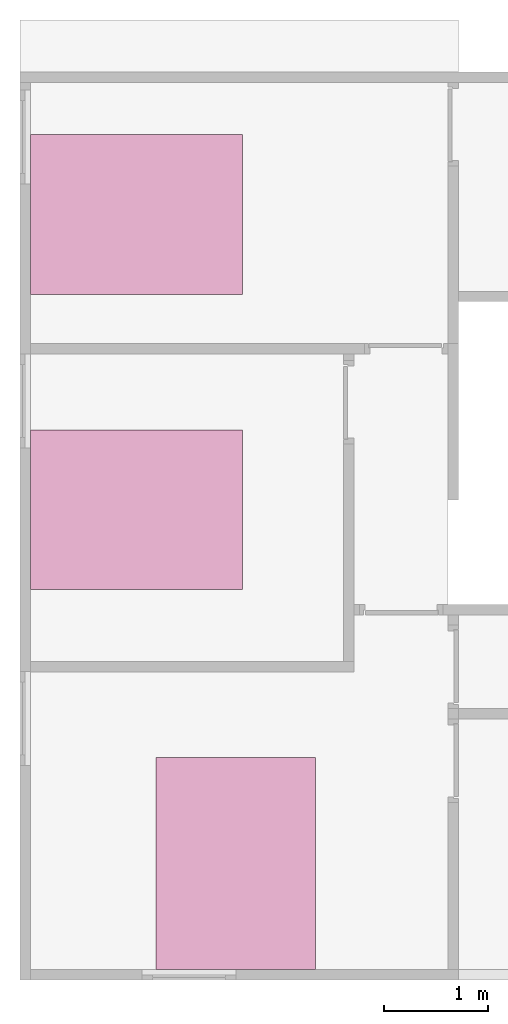
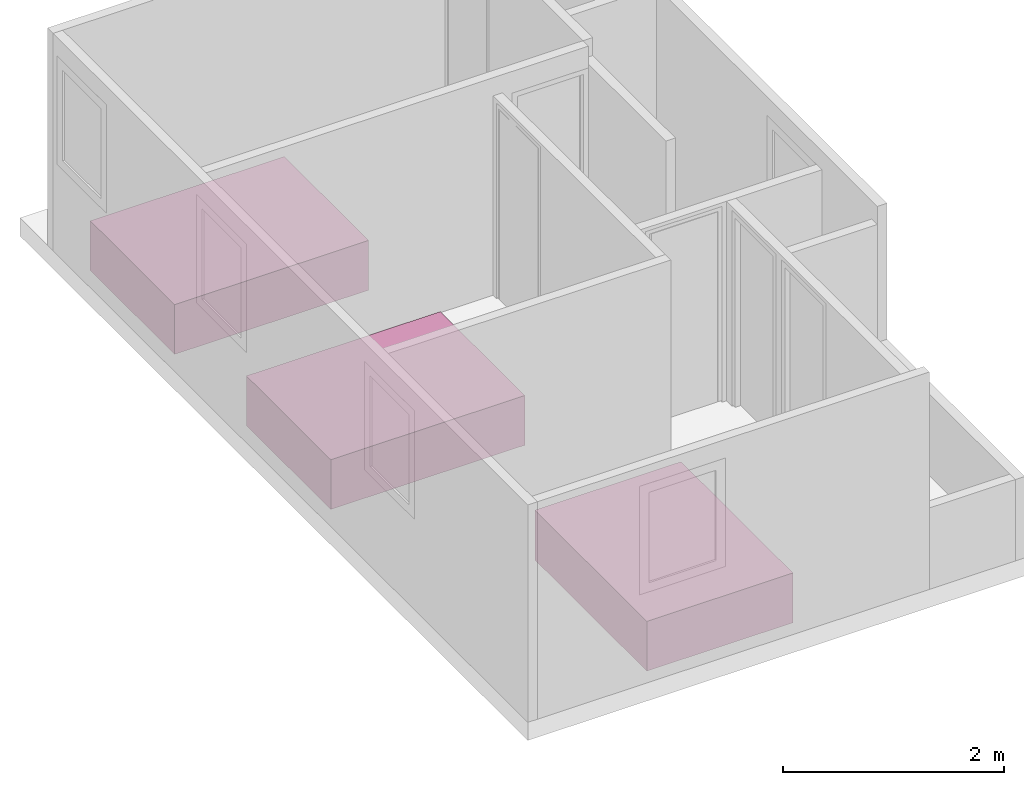
# One storey, part 3 of 3: 3 furniture elements.
"""IFC4 building model written with IfcOpenShell, lengths in millimetres."""

from ifc_helpers import new_model, entity, si_unit, converted_unit, frame, origin_with_axes, origin_2d_with_axis, place, context, subcontext, project, spatial, line, indexed_curve, outline, extrude, source, transform, mapped, type_object, type_shapes, element, save


model = new_model("IFC4")

# Units and contexts
model_context = context("Model", 3, precision=1e-05, world=origin_with_axes())
plan_context = context("Plan", 2, precision=1e-05, world=origin_2d_with_axis())
body_context = subcontext(model_context, "Body", "Model", "MODEL_VIEW")
ifc_project = project(units=[si_unit("LENGTHUNIT", "METRE", prefix="MILLI"), converted_unit("PLANEANGLEUNIT", "degree", entity("IfcReal", 0.0174532925199433), si_unit("PLANEANGLEUNIT", "RADIAN"), dimensions=[0, 0, 0, 0, 0, 0, 0]), si_unit("AREAUNIT", "SQUARE_METRE", prefix="MILLI"), si_unit("VOLUMEUNIT", "CUBIC_METRE", prefix="MILLI")], contexts=[model_context, plan_context])

# Site, building, storey
site_placement = place(None, origin_with_axes())
site = spatial("IfcSite", under=ifc_project, at=site_placement)
building_placement = place(site_placement, origin_with_axes())
building = spatial("IfcBuilding", under=site, at=building_placement, Name="Building")
storey_placement = place(building_placement, frame((0.0, 0.0, 4810.0004196167), z_axis=(0.0, 0.0, 1.0), x_axis=(1.0, 0.0, 0.0)))
storey = spatial("IfcBuildingStorey", under=building, at=storey_placement, Name="2nd FLOOR")

# Furniture
furniture_type = type_object("IfcFurnitureType", Name="Queen bed", AssemblyPlace="NOTDEFINED", PredefinedType="NOTDEFINED")
shared_shape = source(origin_with_axes(), body_context, "Body", "SweptSolid", [
    extrude(outline(indexed_curve([(0.0, 0.0), (0.0, 2030.0), (1530.0, 2030.0), (1530.0, 0.0)], segments=[line(1, 2), line(2, 3), line(3, 4), line(4, 1)])), origin_with_axes(), (0.0, 0.0, 1.0), 550.0),
])
type_shapes(furniture_type, [shared_shape])
for number, where, z_axis, x_axis, name in (
    (1, (2129.99963760376, -2628.94797325134, 50.0001907348633), (0.0, 0.0, 1.0), (-4.37113882867379e-08, 1.0, 0.0), "Furniture"),
    (2, (2129.99963760376, -5457.42130279541, 50.0001907348633), (0.0, 0.0, 1.0), (-4.37113882867379e-08, 1.0, 0.0), "Furniture"),
    (3, (2832.90147781372, -7070.00207901001, 50.0001907348633), (0.0, 0.0, 1.0), (-1.0, -3.25841369885893e-07, 0.0), "Furniture"),
):
    element("IfcFurniture", number, at=place(storey_placement, frame(where, z_axis=z_axis, x_axis=x_axis)), inside=storey, type_object=furniture_type, Name=name, PredefinedType="NOTDEFINED", context=body_context, shape_type="MappedRepresentation", body=[
        mapped(shared_shape, transform((0.0, 0.0, 0.0), x_axis=(1.0, 0.0, 0.0), y_axis=(0.0, 1.0, 0.0), z_axis=(0.0, 0.0, 1.0), scale=1.0)),
    ])

save(model, "model.ifc")
